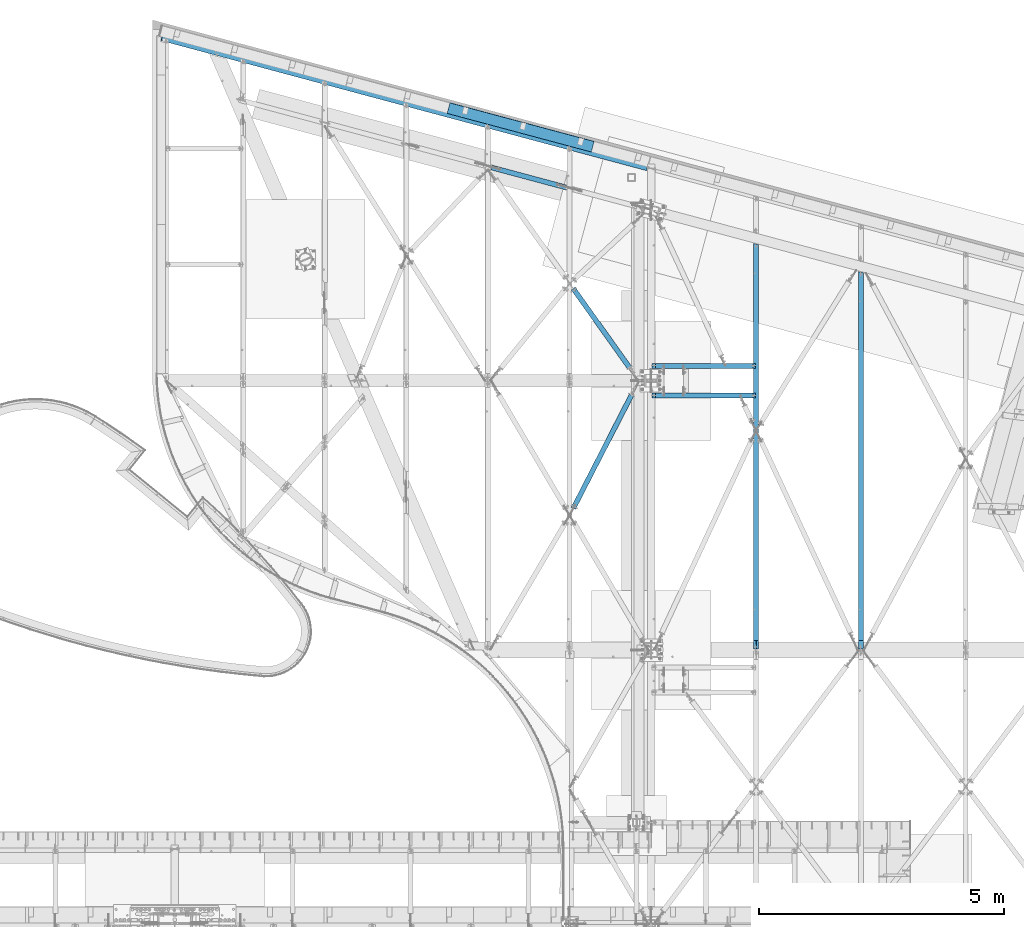
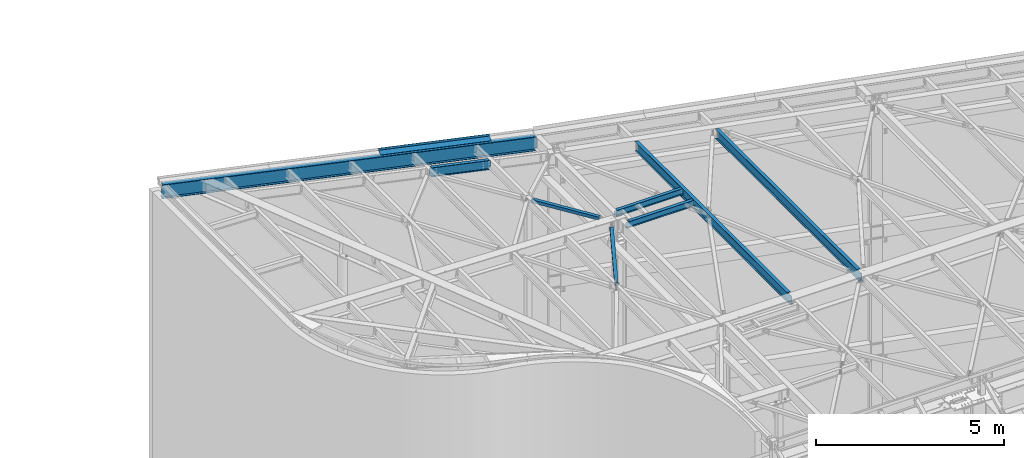
# One storey, part 1158 of 1763: 9 beams, 8 elements without a shape of their own.
"""IFC2X3 building model written with IfcOpenShell, lengths in millimetres."""

from ifc_helpers import new_model, si_unit, frame, origin_with_axes, place, context, subcontext, project, spatial, faceted_brep, material, type_object, element, aggregate, save


model = new_model("IFC2X3")

# Units and contexts
model_context = context("Model", 3, precision=1e-05, world=origin_with_axes())
body_context = subcontext(model_context, "Body", "Model", "MODEL_VIEW")
ifc_project = project(units=[si_unit("LENGTHUNIT", "METRE", prefix="MILLI"), si_unit("AREAUNIT", "SQUARE_METRE"), si_unit("VOLUMEUNIT", "CUBIC_METRE"), si_unit("MASSUNIT", "GRAM", prefix="KILO"), si_unit("TIMEUNIT", "SECOND"), si_unit("PLANEANGLEUNIT", "RADIAN"), si_unit("SOLIDANGLEUNIT", "STERADIAN"), si_unit("THERMODYNAMICTEMPERATUREUNIT", "DEGREE_CELSIUS"), si_unit("LUMINOUSINTENSITYUNIT", "LUMEN")], contexts=[model_context])

# Site, building, storey
site_placement = place(None, origin_with_axes())
site = spatial("IfcSite", under=ifc_project, at=site_placement, CompositionType="ELEMENT")
building_placement = place(site_placement, origin_with_axes())
building = spatial("IfcBuilding", under=site, at=building_placement, Name="Undefined", CompositionType="ELEMENT")
storey_placement = place(building_placement, origin_with_axes())
storey = spatial("IfcBuildingStorey", under=building, at=storey_placement, Name="Undefined", CompositionType="ELEMENT", Elevation=0.0)

# Assembly, beam
assembly_1_placement = place(storey_placement, origin_with_axes())
assembly_1 = element("IfcElementAssembly", 1, at=assembly_1_placement, inside=storey, Name="BEAM", AssemblyPlace="NOTDEFINED", PredefinedType="RIGID_FRAME")
ifc_material_1 = material(Name="STEEL/A992")
beam_type_1 = type_object("IfcBeamType", Name="W8X10", PredefinedType="NOTDEFINED")
beam_1_placement = place(assembly_1_placement, frame((-39672.2896174484, 63506.35, 12345.9875), z_axis=(0.0, 0.0, 1.0), x_axis=(1.0, 0.0, 0.0)))
beam_1 = element("IfcBeam", 2, at=beam_1_placement, type_object=beam_type_1, material=ifc_material_1, Name="BEAM", ObjectType="W8X10", context=body_context, shape_type="Brep", body=[
    faceted_brep([(16.6687500075204, -2.38124999999854, -95.25), (16.6687500075204, -50.8000000000029, -95.25), (2124.075, -50.8000000000029, -95.25), (2124.075, -2.38124999999854, -95.25), (16.6687500075204, -50.8000000000029, -100.012500000001), (2124.075, -50.8000000000029, -100.012500000001), (16.6687500075204, 50.8000000000029, -100.012500000001), (2124.075, 50.8000000000029, -100.012500000001), (16.6687500075204, 50.8000000000029, -95.25), (2124.075, 50.8000000000029, -95.25), (2073.27499999999, -50.8000000000029, 100.012500000001), (2073.27499999999, -50.8000000000029, 95.25), (2073.27499999999, -2.38124999999854, 95.25), (2073.27499999999, -2.38124999999854, 93.4024995803829), (2073.27499999999, 2.38124999999854, 93.4024995803829), (2073.27499999999, 2.38124999999854, 95.25), (2073.27499999999, 50.8000000000029, 95.25), (2073.27499999999, 50.8000000000029, 100.012500000001), (2074.24172992259, -2.38124999999854, 88.5424200623365), (2074.24172992259, 2.38124999999854, 88.5424200623365), (2076.99474382306, -2.38124999999854, 84.4222435941829), (2076.99474382306, 2.38124999999854, 84.4222435941829), (2081.11492029121, -2.38124999999854, 81.6692296937053), (2081.11492029121, 2.38124999999854, 81.6692296937053), (2085.97499980926, -2.38124999999854, 80.7024997711178), (2085.97499980926, 2.38124999999854, 80.7024997711178), (2124.075, -2.38124999999854, 80.7024997711178), (2124.075, 2.38124999999854, 80.7024997711178), (2124.075, 2.38124999999854, -95.25), (16.6687500075204, 2.38124999999854, -95.25), (81.0600766645366, -2.38124999999854, 72.4042299225875), (81.0600766645366, 2.38124999999854, 72.4042299225875), (76.1999971464902, 2.38124999999854, 71.4375), (76.1999971464902, -2.38124999999854, 71.4375), (85.1802531326903, -2.38124999999854, 75.1572438230651), (85.1802531326903, 2.38124999999854, 75.1572438230651), (87.9332670331642, -2.38124999999854, 79.2774202912187), (87.9332670331642, 2.38124999999854, 79.2774202912187), (88.8999969557553, -2.38124999999854, 84.1374998092651), (88.8999969557553, 2.38124999999854, 84.1374998092651), (16.6687500075204, 2.38124999999854, 71.4375), (88.8999969557553, 2.38124999999854, 95.25), (88.8999969557553, 50.8000000000029, 95.25), (88.8999969557553, 50.8000000000029, 100.012500000001), (88.8999969557553, -50.8000000000029, 100.012500000001), (88.8999969557553, -50.8000000000029, 95.25), (88.8999969557553, -2.38124999999854, 95.25), (16.6687500075204, -2.38124999999854, 71.4375)], [[[0, 1, 2, 3]], [[1, 4, 5, 2]], [[4, 6, 7, 5]], [[6, 8, 9, 7]], [[10, 11, 12, 13, 14, 15, 16, 17]], [[18, 19, 14, 13]], [[20, 21, 19, 18]], [[22, 23, 21, 20]], [[24, 25, 23, 22]], [[26, 27, 25, 24]], [[3, 2, 5, 7, 9, 28, 27, 26]], [[8, 29, 28, 9]], [[30, 31, 32, 33]], [[34, 35, 31, 30]], [[36, 37, 35, 34]], [[38, 39, 37, 36]], [[28, 29, 40, 32, 31, 35, 37, 39, 41, 15, 14, 19, 21, 23, 25, 27]], [[41, 42, 16, 15]], [[42, 43, 17, 16]], [[43, 44, 10, 17]], [[44, 45, 11, 10]], [[45, 46, 12, 11]], [[44, 43, 42, 41, 39, 38, 46, 45]], [[22, 20, 18, 13, 12, 46, 38, 36, 34, 30, 33, 47, 0, 3, 26, 24]], [[29, 8, 6, 4, 1, 0, 47, 40]], [[33, 32, 40, 47]]]),
])
aggregate(assembly_1, [beam_1])

assembly_2_placement = place(storey_placement, origin_with_axes())
assembly_2 = element("IfcElementAssembly", 3, at=assembly_2_placement, inside=storey, Name="BEAM", AssemblyPlace="NOTDEFINED", PredefinedType="RIGID_FRAME")
beam_2_placement = place(assembly_2_placement, frame((-39672.2896174484, 62896.75, 12345.9875), z_axis=(0.0, 0.0, 1.0), x_axis=(1.0, 0.0, 0.0)))
beam_2 = element("IfcBeam", 4, at=beam_2_placement, type_object=beam_type_1, material=ifc_material_1, Name="BEAM", ObjectType="W8X10", context=body_context, shape_type="Brep", body=[
    faceted_brep([(16.6687500075204, -2.38124999999854, -95.25), (16.6687500075204, -50.8000000000029, -95.25), (2124.075, -50.8000000000029, -95.25), (2124.075, -2.38124999999854, -95.25), (16.6687500075204, -50.8000000000029, -100.012500000001), (2124.075, -50.8000000000029, -100.012500000001), (16.6687500075204, 50.8000000000029, -100.012500000001), (2124.075, 50.8000000000029, -100.012500000001), (16.6687500075204, 50.8000000000029, -95.25), (2124.075, 50.8000000000029, -95.25), (2073.27499999999, -50.8000000000029, 100.012500000001), (2073.27499999999, -50.8000000000029, 95.25), (2073.27499999999, -2.38124999999854, 95.25), (2073.27499999999, -2.38124999999854, 93.4024995803829), (2073.27499999999, 2.38124999999854, 93.4024995803829), (2073.27499999999, 2.38124999999854, 95.25), (2073.27499999999, 50.8000000000029, 95.25), (2073.27499999999, 50.8000000000029, 100.012500000001), (2074.24172992259, -2.38124999999854, 88.5424200623365), (2074.24172992259, 2.38124999999854, 88.5424200623365), (2076.99474382306, -2.38124999999854, 84.4222435941829), (2076.99474382306, 2.38124999999854, 84.4222435941829), (2081.11492029121, -2.38124999999854, 81.6692296937053), (2081.11492029121, 2.38124999999854, 81.6692296937053), (2085.97499980926, -2.38124999999854, 80.7024997711178), (2085.97499980926, 2.38124999999854, 80.7024997711178), (2124.075, -2.38124999999854, 80.7024997711178), (2124.075, 2.38124999999854, 80.7024997711178), (2124.075, 2.38124999999854, -95.25), (16.6687500075204, 2.38124999999854, -95.25), (81.0600766645366, -2.38124999999854, 72.4042299225875), (81.0600766645366, 2.38124999999854, 72.4042299225875), (76.1999971464902, 2.38124999999854, 71.4375), (76.1999971464902, -2.38124999999854, 71.4375), (85.1802531326903, -2.38124999999854, 75.1572438230651), (85.1802531326903, 2.38124999999854, 75.1572438230651), (87.9332670331642, -2.38124999999854, 79.2774202912187), (87.9332670331642, 2.38124999999854, 79.2774202912187), (88.8999969557553, -2.38124999999854, 84.1374998092651), (88.8999969557553, 2.38124999999854, 84.1374998092651), (16.6687500075204, 2.38124999999854, 71.4375), (88.8999969557553, 2.38124999999854, 95.25), (88.8999969557553, 50.8000000000029, 95.25), (88.8999969557553, 50.8000000000029, 100.012500000001), (88.8999969557553, -50.8000000000029, 100.012500000001), (88.8999969557553, -50.8000000000029, 95.25), (88.8999969557553, -2.38124999999854, 95.25), (16.6687500075204, -2.38124999999854, 71.4375)], [[[0, 1, 2, 3]], [[1, 4, 5, 2]], [[4, 6, 7, 5]], [[6, 8, 9, 7]], [[10, 11, 12, 13, 14, 15, 16, 17]], [[18, 19, 14, 13]], [[20, 21, 19, 18]], [[22, 23, 21, 20]], [[24, 25, 23, 22]], [[26, 27, 25, 24]], [[3, 2, 5, 7, 9, 28, 27, 26]], [[8, 29, 28, 9]], [[30, 31, 32, 33]], [[34, 35, 31, 30]], [[36, 37, 35, 34]], [[38, 39, 37, 36]], [[28, 29, 40, 32, 31, 35, 37, 39, 41, 15, 14, 19, 21, 23, 25, 27]], [[41, 42, 16, 15]], [[42, 43, 17, 16]], [[43, 44, 10, 17]], [[44, 45, 11, 10]], [[45, 46, 12, 11]], [[44, 43, 42, 41, 39, 38, 46, 45]], [[22, 20, 18, 13, 12, 46, 38, 36, 34, 30, 33, 47, 0, 3, 26, 24]], [[29, 8, 6, 4, 1, 0, 47, 40]], [[33, 32, 40, 47]]]),
])
aggregate(assembly_2, [beam_2])

assembly_3_placement = place(storey_placement, origin_with_axes())
assembly_3 = element("IfcElementAssembly", 5, at=assembly_3_placement, inside=storey, Name="H. BRACE", AssemblyPlace="NOTDEFINED", PredefinedType="RIGID_FRAME")
ifc_material_2 = material()
beam_type_2 = type_object("IfcBeamType", Name="HSS4X4X3/8", PredefinedType="NOTDEFINED")
beam_3_placement = place(assembly_3_placement, frame((-39926.28961746, 63201.5499999792, 12371.3875), z_axis=(0.0, 0.0, 1.0), x_axis=(-0.456931592097528, -0.889501838189904, 0.0)))
beam_3 = element("IfcBeam", 6, at=beam_3_placement, type_object=beam_type_2, material=ifc_material_2, Name="H. BRACE", ObjectType="HSS4X4X3/8", context=body_context, shape_type="Brep", body=[
    faceted_brep([(2929.29386825136, 6.34999999801948, 50.7999999999993), (2852.25306472532, 6.34999999799038, 50.7999999999993), (2852.25306472532, 6.34999999799038, 41.2749999999996), (2929.29386825136, 6.34999999801948, 41.2749999999996), (2852.25306472532, -6.35000000193395, 50.7999999999993), (2852.25306472532, -6.35000000193395, 41.2749999999996), (2929.29386825136, -6.35000000190485, 50.7999999999993), (2929.29386825136, -6.35000000190485, 41.2749999999996), (2929.29386825136, 6.34999999801948, -41.2749999999996), (2852.25306472532, 6.34999999799038, -41.2749999999996), (2852.25306472532, 6.34999999799038, -50.7999999999993), (2929.29386825136, 6.34999999801948, -50.7999999999993), (2852.25306472532, -6.35000000193395, -41.2749999999996), (2852.25306472532, -6.35000000193395, -50.7999999999993), (2929.29386825136, -6.35000000190485, -41.2749999999996), (2929.29386825136, -6.35000000190485, -50.7999999999993), (333.207496843585, 41.2750000000451, 41.2749999999996), (333.207496879448, 41.2750000000451, -41.2749999999996), (2929.29386825136, 41.2750000010346, -41.2749999999996), (2929.29386825136, 41.2750000010346, 41.2749999999996), (2929.29386825135, -41.2749999987864, 41.2749999999996), (333.207496855881, -41.2749999997759, 41.2749999999996), (333.207496891722, -41.2749999997832, -41.2749999999996), (2929.29386825135, -41.2749999987864, -41.2749999999996), (333.207496897281, -50.7999999997483, -50.7999999999993), (333.207496853145, -50.7999999997628, 50.7999999999993), (333.20749683804, 50.8000000000247, 50.7999999999993), (333.207496882162, 50.8000000000247, -50.7999999999993), (2929.29386825135, 50.8000000010143, 50.7999999999993), (2929.29386825135, 50.8000000010143, -50.7999999999993), (2929.29386825134, -50.7999999987733, -50.7999999999993), (2929.29386825134, -50.7999999987733, 50.7999999999993)], [[[0, 1, 2, 3]], [[4, 5, 2, 1]], [[6, 7, 5, 4]], [[8, 9, 10, 11]], [[12, 13, 10, 9]], [[14, 15, 13, 12]], [[16, 17, 18, 19]], [[20, 21, 16, 19, 3, 2, 5, 7]], [[22, 21, 20, 23]], [[9, 8, 18, 17, 22, 23, 14, 12]], [[24, 25, 26, 27], [16, 21, 22, 17]], [[27, 26, 28, 29]], [[19, 18, 8, 11, 29, 28, 0, 3]], [[30, 24, 27, 29, 11, 10, 13, 15]], [[25, 24, 30, 31]], [[1, 0, 28, 26, 25, 31, 6, 4]], [[31, 30, 15, 14, 23, 20, 7, 6]]]),
])
aggregate(assembly_3, [beam_3])

assembly_4_placement = place(storey_placement, origin_with_axes())
assembly_4 = element("IfcElementAssembly", 7, at=assembly_4_placement, inside=storey, Name="H. BRACE", AssemblyPlace="NOTDEFINED", PredefinedType="RIGID_FRAME")
beam_4_placement = place(assembly_4_placement, frame((-39926.2896186417, 63201.549999171, 12382.5), z_axis=(0.0, 0.0, 1.0), x_axis=(-0.58011823790282, 0.814532276863555, 0.0)))
beam_4 = element("IfcBeam", 8, at=beam_4_placement, type_object=beam_type_2, material=ifc_material_2, Name="H. BRACE", ObjectType="HSS4X4X3/8", context=body_context, shape_type="Brep", body=[
    faceted_brep([(2313.8306568805, 6.35000000507716, 50.7999999999993), (2236.51765652429, 6.3500000051572, 50.7999999999993), (2236.51765652429, 6.3500000051572, 41.2749999999996), (2313.8306568805, 6.35000000507716, 41.2749999999996), (2236.51765652427, -6.3499999947162, 50.7999999999993), (2236.51765652427, -6.3499999947162, 41.2749999999996), (2313.8306568805, -6.34999999480351, 50.7999999999993), (2313.8306568805, -6.34999999480351, 41.2749999999996), (2313.8306568805, 6.35000000507716, -41.2749999999996), (2236.51765652429, 6.3500000051572, -41.2749999999996), (2236.51765652429, 6.3500000051572, -50.7999999999993), (2313.8306568805, 6.35000000507716, -50.7999999999993), (2236.51765652427, -6.3499999947162, -41.2749999999996), (2236.51765652427, -6.3499999947162, -50.7999999999993), (2313.8306568805, -6.34999999480351, -41.2749999999996), (2313.8306568805, -6.34999999480351, -50.7999999999993), (334.490460568326, 41.2749999995031, 41.2749999999996), (334.490460596047, 41.2749999995031, -41.2749999999996), (2313.8306568805, 41.2749999974403, -41.2749999999996), (2313.8306568805, 41.2749999974403, 41.2749999999996), (2313.8306568805, -41.2750000022861, 41.2749999999996), (334.490460587243, -41.2750000002161, 41.2749999999996), (334.490460614965, -41.2750000002125, -41.2749999999996), (2313.8306568805, -41.2750000022861, -41.2749999999996), (334.490460620349, -50.8000000001812, -50.7999999999993), (334.490460586225, -50.8000000001884, 50.7999999999993), (334.490460562942, 50.7999999994754, 50.7999999999993), (334.490460597051, 50.7999999994718, -50.7999999999993), (2313.8306568805, 50.7999999973981, 50.7999999999993), (2313.8306568805, 50.7999999973981, -50.7999999999993), (2313.8306568805, -50.8000000022512, -50.7999999999993), (2313.8306568805, -50.8000000022512, 50.7999999999993)], [[[0, 1, 2, 3]], [[4, 5, 2, 1]], [[6, 7, 5, 4]], [[8, 9, 10, 11]], [[12, 13, 10, 9]], [[14, 15, 13, 12]], [[16, 17, 18, 19]], [[20, 21, 16, 19, 3, 2, 5, 7]], [[22, 21, 20, 23]], [[9, 8, 18, 17, 22, 23, 14, 12]], [[24, 25, 26, 27], [16, 21, 22, 17]], [[27, 26, 28, 29]], [[19, 18, 8, 11, 29, 28, 0, 3]], [[30, 24, 27, 29, 11, 10, 13, 15]], [[25, 24, 30, 31]], [[1, 0, 28, 26, 25, 31, 6, 4]], [[31, 30, 15, 14, 23, 20, 7, 6]]]),
])
aggregate(assembly_4, [beam_4])

assembly_5_placement = place(storey_placement, origin_with_axes())
assembly_5 = element("IfcElementAssembly", 9, at=assembly_5_placement, inside=storey, Name="BEAM", AssemblyPlace="NOTDEFINED", PredefinedType="RIGID_FRAME")
ifc_material_3 = material(Name="STEEL/A36")
beam_type_3 = type_object("IfcBeamType", PredefinedType="NOTDEFINED")
beam_5_placement = place(assembly_5_placement, frame((-42369.7578843435, 68265.4761425118, 12531.2711538973), z_axis=(-0.965507252027915, 0.25870688944179, 0.0294362300041612), x_axis=(0.258819045079128, 0.965925826295336, 0.0)))
beam_5 = element("IfcBeam", 10, at=beam_5_placement, type_object=beam_type_3, material=ifc_material_3, Name="BENT_PLATE", context=body_context, shape_type="Brep", body=[
    faceted_brep([(0.0, -3.17499999999927, -1523.99999999999), (0.0, -3.17499999999927, 1524.0), (0.0, 3.17499999999927, 1524.0), (0.0, 3.17499999999927, -1523.99999999999), (228.599995165183, 3.17499993969795, 1523.99999998704), (228.599994834185, 3.17499994154787, -1524.00000000063), (222.249995293445, -3.17500005680085, -1524.00000000046), (222.249995624443, -3.17500005865077, 1523.99999998722), (228.600000545521, -73.0249989343301, 1523.99999998058), (228.600000477083, -73.0249986697763, -1524.00000000709), (222.250000545486, -73.0249993936013, 1523.99999998076), (222.250000477034, -73.0249991290493, -1524.0000000069)], [[[0, 1, 2, 3]], [[3, 2, 4, 5]], [[1, 0, 6, 7]], [[5, 4, 8, 9]], [[4, 2, 1, 7, 10, 8]], [[7, 6, 11, 10]], [[6, 0, 3, 5, 9, 11]], [[10, 11, 9, 8]]]),
])

assembly_6_placement = place(storey_placement, origin_with_axes())
assembly_6 = element("IfcElementAssembly", 11, at=assembly_6_placement, inside=storey, Name="BEAM", AssemblyPlace="NOTDEFINED", PredefinedType="RIGID_FRAME")
beam_type_4 = type_object("IfcBeamType", Name="W12X16", PredefinedType="NOTDEFINED")
beam_6_placement = place(assembly_6_placement, frame((-37532.3396174484, 57702.45, 12293.6), z_axis=(0.0, 0.0, 1.0), x_axis=(0.0, 1.0, 0.0)))
beam_6 = element("IfcBeam", 12, at=beam_6_placement, type_object=beam_type_4, material=ifc_material_1, Name="BEAM", ObjectType="W12X16", context=body_context, shape_type="Brep", body=[
    faceted_brep([(20.637499999335, -3.17500000023574, -146.050000000019), (20.637499999335, -50.8000000002503, -146.05000000003), (8273.61080945563, -50.8000000000029, -146.049999999999), (8286.37188974393, -3.17500000000291, -146.049999999999), (20.637499999335, -50.8000000002576, -152.400000000032), (8273.61080945563, -50.8000000000029, -152.4), (20.637499999335, 50.7999999997701, -152.400000000003), (8300.834447404, 50.8000000000029, -152.4), (20.637499999335, 50.7999999997774, -146.050000000005), (8300.834447404, 50.8000000000029, -146.049999999999), (8288.0733671157, 3.17500000000291, -146.049999999999), (8288.0733671157, 3.17500000000291, 146.049999999999), (8300.834447404, 50.8000000000029, 146.049999999999), (8300.834447404, 50.8000000000029, 152.4), (8273.61080945563, -50.8000000000029, 152.4), (8273.61080945563, -50.8000000000029, 146.049999999999), (8286.37188974393, -3.17500000000291, 146.049999999999), (20.637499999335, 3.17499999977008, -146.050000000016), (184.247579708775, -3.17500000000291, 115.006731601054), (184.247579708775, 3.17500000000291, 115.006731601054), (179.387500190729, 3.17500000000291, 114.040001678466), (179.387500190729, -3.17500000000291, 114.040001678466), (188.367756176929, -3.17500000000291, 117.759745501531), (188.367756176929, 3.17500000000291, 117.759745501531), (191.120770077403, -3.17500000000291, 121.879921969685), (191.120770077403, 3.17500000000291, 121.879921969685), (192.087499999994, -3.17500000000291, 126.740001487731), (192.087499999994, 3.17500000000291, 126.740001487731), (20.6374999999971, 3.17500000000291, 114.040001678466), (192.087499999994, 3.17500000000291, 146.049999999999), (192.087499999994, 50.8000000000029, 146.049999999999), (192.087499999994, 50.8000000000029, 152.4), (192.087499999994, -50.8000000000029, 152.4), (192.087499999994, -50.8000000000029, 146.049999999999), (192.087499999994, -3.17500000000291, 146.049999999999), (20.6374999999971, -3.17500000000291, 114.040001678466)], [[[0, 1, 2, 3]], [[1, 4, 5, 2]], [[4, 6, 7, 5]], [[6, 8, 9, 7]], [[10, 11, 12, 13, 14, 15, 16, 3, 2, 5, 7, 9]], [[8, 17, 10, 9]], [[18, 19, 20, 21]], [[22, 23, 19, 18]], [[24, 25, 23, 22]], [[26, 27, 25, 24]], [[11, 10, 17, 28, 20, 19, 23, 25, 27, 29]], [[12, 11, 29, 30]], [[13, 12, 30, 31]], [[14, 13, 31, 32]], [[15, 14, 32, 33]], [[16, 15, 33, 34]], [[32, 31, 30, 29, 27, 26, 34, 33]], [[24, 22, 18, 21, 35, 0, 3, 16, 34, 26]], [[17, 8, 6, 4, 1, 0, 35, 28]], [[21, 20, 28, 35]]]),
])
aggregate(assembly_6, [beam_6])

assembly_7_placement = place(storey_placement, origin_with_axes())
assembly_7 = element("IfcElementAssembly", 13, at=assembly_7_placement, inside=storey, Name="BEAM", AssemblyPlace="NOTDEFINED", PredefinedType="RIGID_FRAME")
beam_7_placement = place(assembly_7_placement, frame((-35392.3896174484, 57702.45, 12293.6), z_axis=(0.0, 0.0, 1.0), x_axis=(0.0, 1.0, 0.0)))
beam_7 = element("IfcBeam", 14, at=beam_7_placement, type_object=beam_type_4, material=ifc_material_1, Name="BEAM", ObjectType="W12X16", context=body_context, shape_type="Brep", body=[
    faceted_brep([(20.637499999335, -3.17500000023574, -146.050000000019), (20.637499999335, -50.8000000002503, -146.05000000003), (7700.21293518768, -50.8000000000029, -146.049999999999), (7712.97401547598, -3.17500000000291, -146.049999999999), (20.637499999335, -50.8000000002576, -152.400000000032), (7700.21293518768, -50.8000000000029, -152.4), (20.637499999335, 50.7999999997701, -152.400000000003), (7727.43657313604, 50.8000000000029, -152.4), (20.637499999335, 50.7999999997774, -146.050000000005), (7727.43657313604, 50.8000000000029, -146.049999999999), (7714.67549284775, 3.17500000000291, -146.049999999999), (7714.67549284775, 3.17500000000291, 146.049999999999), (7727.43657313604, 50.8000000000029, 146.049999999999), (7727.43657313604, 50.8000000000029, 152.4), (7700.21293518768, -50.8000000000029, 152.4), (7700.21293518768, -50.8000000000029, 146.049999999999), (7712.97401547598, -3.17500000000291, 146.049999999999), (20.637499999335, 3.17499999977008, -146.050000000016), (184.247579708775, -3.17500000000291, 115.006731601054), (184.247579708775, 3.17500000000291, 115.006731601054), (179.387500190729, 3.17500000000291, 114.040001678466), (179.387500190729, -3.17500000000291, 114.040001678466), (188.367756176929, -3.17500000000291, 117.759745501531), (188.367756176929, 3.17500000000291, 117.759745501531), (191.120770077403, -3.17500000000291, 121.879921969685), (191.120770077403, 3.17500000000291, 121.879921969685), (192.087499999994, -3.17500000000291, 126.740001487731), (192.087499999994, 3.17500000000291, 126.740001487731), (20.6374999999971, 3.17500000000291, 114.040001678466), (192.087499999994, 3.17500000000291, 146.049999999999), (192.087499999994, 50.8000000000029, 146.049999999999), (192.087499999994, 50.8000000000029, 152.4), (192.087499999994, -50.8000000000029, 152.4), (192.087499999994, -50.8000000000029, 146.049999999999), (192.087499999994, -3.17500000000291, 146.049999999999), (20.6374999999971, -3.17500000000291, 114.040001678466)], [[[0, 1, 2, 3]], [[1, 4, 5, 2]], [[4, 6, 7, 5]], [[6, 8, 9, 7]], [[10, 11, 12, 13, 14, 15, 16, 3, 2, 5, 7, 9]], [[8, 17, 10, 9]], [[18, 19, 20, 21]], [[22, 23, 19, 18]], [[24, 25, 23, 22]], [[26, 27, 25, 24]], [[11, 10, 17, 28, 20, 19, 23, 25, 27, 29]], [[12, 11, 29, 30]], [[13, 12, 30, 31]], [[14, 13, 31, 32]], [[15, 14, 32, 33]], [[16, 15, 33, 34]], [[32, 31, 30, 29, 27, 26, 34, 33]], [[24, 22, 18, 21, 35, 0, 3, 16, 34, 26]], [[17, 8, 6, 4, 1, 0, 35, 28]], [[21, 20, 28, 35]]]),
])
aggregate(assembly_7, [beam_7])

# Beam
beam_type_5 = type_object("IfcBeamType", Name="W18X40", PredefinedType="NOTDEFINED")
beam_8_placement = place(assembly_5_placement, frame((-49666.0274346461, 70220.5056802563, 12523.4313587167), z_axis=(0.0284332150015107, -0.00761865702657088, 0.99956666028324), x_axis=(0.965507252136511, -0.258706889036504, -0.029436230004148)))
beam_8 = element("IfcBeam", 15, at=beam_8_placement, type_object=beam_type_5, material=ifc_material_1, Name="BEAM", ObjectType="W18X40", context=body_context, shape_type="Brep", body=[
    faceted_brep([(10272.8034535879, -76.2000000654662, 214.31249999487), (10253.4407577798, -3.96875006541086, 214.312499994898), (10253.8542611601, -3.96875006531627, 200.271149638753), (10251.72649239, 3.96874993468373, 200.271149639184), (10251.3129890097, 3.96874993460369, 214.3124999949), (10231.9502932015, 76.199999934659, 214.312499994929), (10231.576291215, 76.1999999345717, 227.012499994928), (10272.4294516015, -76.2000000655462, 227.012499994869), (10254.959875623, -3.96875006529444, 195.523051510654), (10252.8321068528, 3.96874993472011, 195.523051511087), (10257.8331485892, -3.96875006527989, 191.525221404559), (10255.7053798191, 3.96874993471283, 191.525221404994), (10262.0521500248, -3.96875006529444, 188.864726616941), (10259.9243812547, 3.96874993472011, 188.864726617374), (10266.9973344012, -3.96875006531627, 187.932251454231), (10264.8695656311, 3.968749934691, 187.932251454664), (10326.9015734239, -3.96875006568735, 187.932251449605), (10326.9015734115, 3.96874993430538, 187.932251449914), (1.89174897968769e-10, -76.1999999984182, -227.012500000012), (1.74622982740402e-10, -76.1999999985128, -214.312500000011), (3.20142135024071e-10, -3.96874999858119, -214.312499999995), (-3.34694050252438e-10, -3.96875000142609, 214.312499999991), (-4.80213202536106e-10, -76.2000000013722, 214.312499999973), (-5.0931703299284e-10, -76.200000001445, 227.012499999972), (-1.89174897968769e-10, 76.1999999984109, 227.01250000001), (-1.89174897968769e-10, 76.1999999984982, 214.312500000009), (-3.20142135024071e-10, 3.96874999856664, 214.312499999993), (3.34694050252438e-10, 3.96875000140426, -214.312499999991), (4.80213202536106e-10, 76.2000000013577, -214.312499999975), (4.94765117764473e-10, 76.2000000014305, -227.012499999973), (10263.9355631693, 3.96874993737583, -214.312500005091), (10244.5728673612, 76.1999999374311, -214.312500005062), (10244.9468711973, 76.1999999375184, -227.012500005063), (10285.8000315838, -76.2000000625994, -227.012500005119), (10285.4260277476, -76.2000000626795, -214.31250000512), (10266.0633319394, -3.96875006263144, -214.312500005095), (10263.5821871364, 3.96874993731035, -202.312955666757), (10265.7099559065, -3.96875006269693, -202.312955667188), (10264.4731886453, 3.96874993726669, -197.343104861602), (10266.6009574154, -3.96875006274786, -197.343104862033), (10267.2966947312, 3.96874993720849, -193.10018625771), (10269.4244635014, -3.96875006279151, -193.100186258145), (10271.6073571644, 3.96874993717211, -190.253430319579), (10273.7351259345, -3.96875006283517, -190.25343032001), (10276.7252603273, 3.96874993712117, -189.2518524483), (10278.8530290974, -3.96875006287883, -189.251852448735), (10338.0092648649, -3.9687500632499, -189.251852456213), (10338.0092648538, 3.96874993673555, -189.251852455915)], [[[0, 1, 2, 3, 4, 5, 6, 7]], [[8, 9, 3, 2]], [[10, 11, 9, 8]], [[12, 13, 11, 10]], [[14, 15, 13, 12]], [[16, 17, 15, 14]], [[18, 19, 20, 21, 22, 23, 24, 25, 26, 27, 28, 29]], [[28, 27, 30, 31]], [[29, 28, 31, 32]], [[18, 29, 32, 33]], [[19, 18, 33, 34]], [[20, 19, 34, 35]], [[33, 32, 31, 30, 36, 37, 35, 34]], [[37, 36, 38, 39]], [[39, 38, 40, 41]], [[41, 40, 42, 43]], [[43, 42, 44, 45]], [[46, 45, 44, 47]], [[12, 10, 8, 2, 1, 21, 20, 35, 37, 39, 41, 43, 45, 46, 16, 14]], [[22, 21, 1, 0]], [[23, 22, 0, 7]], [[24, 23, 7, 6]], [[25, 24, 6, 5]], [[26, 25, 5, 4]], [[47, 44, 42, 40, 38, 36, 30, 27, 26, 4, 3, 9, 11, 13, 15, 17]], [[46, 47, 17, 16]]]),
])

aggregate(assembly_5, [beam_5, beam_8])

# Assembly, beam
assembly_8_placement = place(storey_placement, origin_with_axes())
assembly_8 = element("IfcElementAssembly", 16, at=assembly_8_placement, inside=storey, Name="BEAM", AssemblyPlace="NOTDEFINED", PredefinedType="RIGID_FRAME")
beam_type_6 = type_object("IfcBeamType", Name="W12X14", PredefinedType="NOTDEFINED")
beam_9_placement = place(assembly_8_placement, frame((-43008.667277575, 67575.3822698406, 12396.8410650766), z_axis=(0.0284332150015107, -0.00761865702657088, 0.99956666028324), x_axis=(0.965507252136511, -0.258706889036504, -0.029436230004148)))
beam_9 = element("IfcBeam", 17, at=beam_9_placement, type_object=beam_type_6, material=ifc_material_1, Name="BEAM", ObjectType="W12X14", context=body_context, shape_type="Brep", body=[
    faceted_brep([(1673.27505289909, -50.7999999977692, 150.812500001271), (1673.26846174494, -50.7999999977765, 144.462500001275), (1660.30071521789, -2.38124999773572, 144.462500001255), (1660.28066042485, -2.38124999775755, 125.141462331452), (1659.00514437303, 2.38125000225409, 125.14146233178), (1659.02519916605, 2.38125000226137, 144.462500001251), (1646.057452639, 50.8000000022803, 144.462500001235), (1646.06404379315, 50.8000000022948, 150.812500001231), (1661.27767513196, -2.38124999775027, 120.277473846285), (1660.00215908013, 2.38125000224682, 120.277473846612), (1664.12683687208, -2.38124999776483, 116.15297593206), (1662.85132082026, 2.38125000223954, 116.152975932388), (1668.39383982998, -2.38124999775027, 113.396677518758), (1667.11832377816, 2.38125000224682, 113.396677519089), (1673.4282526272, -2.38124999775027, 112.428729000971), (1672.15273657539, 2.38125000226864, 112.428729001298), (1708.29546927322, -2.38124999769934, 112.428729005967), (1708.29546930385, 2.38125000230502, 112.428729006491), (79.4520183159912, -50.7999999998283, 150.812500000036), (52.2410092100545, 50.8000000002357, 150.812499999996), (52.2344178961284, 50.8000000002285, 144.462499999998), (65.2021644231863, 2.381250000195, 144.462500000018), (65.180338406135, 2.38125000018044, 123.43555347144), (66.4558544579486, -2.38124999981665, 123.43555347111), (66.4776804750218, -2.38124999980937, 144.46250000002), (79.4454270020797, -50.7999999998283, 144.462500000038), (64.1757566347005, 2.38125000018772, 118.57938576362), (65.4512726865214, -2.38124999982392, 118.579385763293), (61.3248405516133, 2.38125000016589, 114.463530354966), (62.6003566034269, -2.3812499998312, 114.463530354638), (57.0610694999559, 2.38125000016589, 111.713799527155), (58.3365855517768, -2.38124999983847, 111.713799526828), (52.0327462079658, 2.38125000015862, 110.748287492082), (53.3082622597867, -2.38124999984575, 110.748287491755), (17.1391654221006, 2.38125000011496, 110.748287487138), (17.1391654510226, -2.38124999988941, 110.74828748662), (16.8986552047136, 2.38124999994761, -120.957073808284), (16.8986553872819, -2.38125000005675, -120.957073808802), (51.7658723345521, 2.38124999999127, -120.957073804339), (53.0413883863803, -2.38125000000582, -120.957073804666), (56.8002850028424, 2.38125000000582, -121.925022270514), (58.0758010546633, -2.38125000000582, -121.925022270842), (61.0672878924015, 2.38125000000582, -124.681320544692), (62.3428039442224, -2.38125000000582, -124.68132054502), (63.9164496698431, 2.38125000000582, -128.805818275905), (65.191965721664, -2.38125000000582, -128.805818276232), (64.9134645374434, 2.38125000000582, -133.669806595592), (66.188980589257, -2.38124999999127, -133.669806595919), (66.1777784955048, -2.38124999999854, -144.462499999918), (79.1455250225554, -50.8000000000393, -144.462499999898), (1672.96855751574, -50.7999999979656, -144.462499998663), (1660.00081098868, -2.38124999793945, -144.462499998681), (79.1389341475224, -50.800000000032, -150.812499999896), (1672.96196583249, -50.7999999979729, -150.812499998659), (51.9279250415784, 50.8000000000247, -150.812499999936), (51.9345159166114, 50.8000000000247, -144.462499999938), (1645.75754840979, 50.8000000020911, -144.462499998703), (1645.75095672654, 50.8000000020911, -150.812499998701), (64.9022624436548, 2.38124999999854, -144.462499999918), (1658.72529493684, 2.38125000205764, -144.462499998683), (1658.73826924035, 2.38125000207219, -131.963897568285), (1660.01378529218, -2.38124999793945, -131.963897568612), (1659.74285122343, 2.38125000206492, -127.107730079737), (1661.01836727525, -2.38124999793217, -127.107730080066), (1662.59376735541, 2.38125000207947, -122.991874913194), (1663.86928340723, -2.3812499979249, -122.991874913523), (1666.85753831639, 2.38125000208674, -120.242144269299), (1668.13305436822, -2.3812499979249, -120.242144269627), (1671.88586143775, 2.38125000210857, -119.276632302444), (1673.16137748957, -2.38124999790307, -119.276632302772), (1708.05495905583, -2.38124999787397, -119.276632298766), (1708.05495924009, 2.38125000213768, -119.276632298244)], [[[0, 1, 2, 3, 4, 5, 6, 7]], [[8, 9, 4, 3]], [[10, 11, 9, 8]], [[12, 13, 11, 10]], [[14, 15, 13, 12]], [[16, 17, 15, 14]], [[18, 19, 20, 21, 22, 23, 24, 25]], [[23, 22, 26, 27]], [[27, 26, 28, 29]], [[29, 28, 30, 31]], [[31, 30, 32, 33]], [[33, 32, 34, 35]], [[35, 34, 36, 37]], [[37, 36, 38, 39]], [[39, 38, 40, 41]], [[41, 40, 42, 43]], [[43, 42, 44, 45]], [[45, 44, 46, 47]], [[48, 49, 50, 51]], [[49, 52, 53, 50]], [[54, 55, 56, 57]], [[52, 54, 57, 53]], [[49, 48, 47, 46, 58, 55, 54, 52]], [[55, 58, 59, 56]], [[50, 53, 57, 56, 59, 60, 61, 51]], [[61, 60, 62, 63]], [[63, 62, 64, 65]], [[65, 64, 66, 67]], [[67, 66, 68, 69]], [[70, 69, 68, 71]], [[12, 10, 8, 3, 2, 24, 23, 27, 29, 31, 33, 35, 37, 39, 41, 43, 45, 47, 48, 51, 61, 63, 65, 67, 69, 70, 16, 14]], [[25, 24, 2, 1]], [[18, 25, 1, 0]], [[19, 18, 0, 7]], [[20, 19, 7, 6]], [[21, 20, 6, 5]], [[71, 68, 66, 64, 62, 60, 59, 58, 46, 44, 42, 40, 38, 36, 34, 32, 30, 28, 26, 22, 21, 5, 4, 9, 11, 13, 15, 17]], [[70, 71, 17, 16]]]),
])
aggregate(assembly_8, [beam_9])

save(model, "model.ifc")
